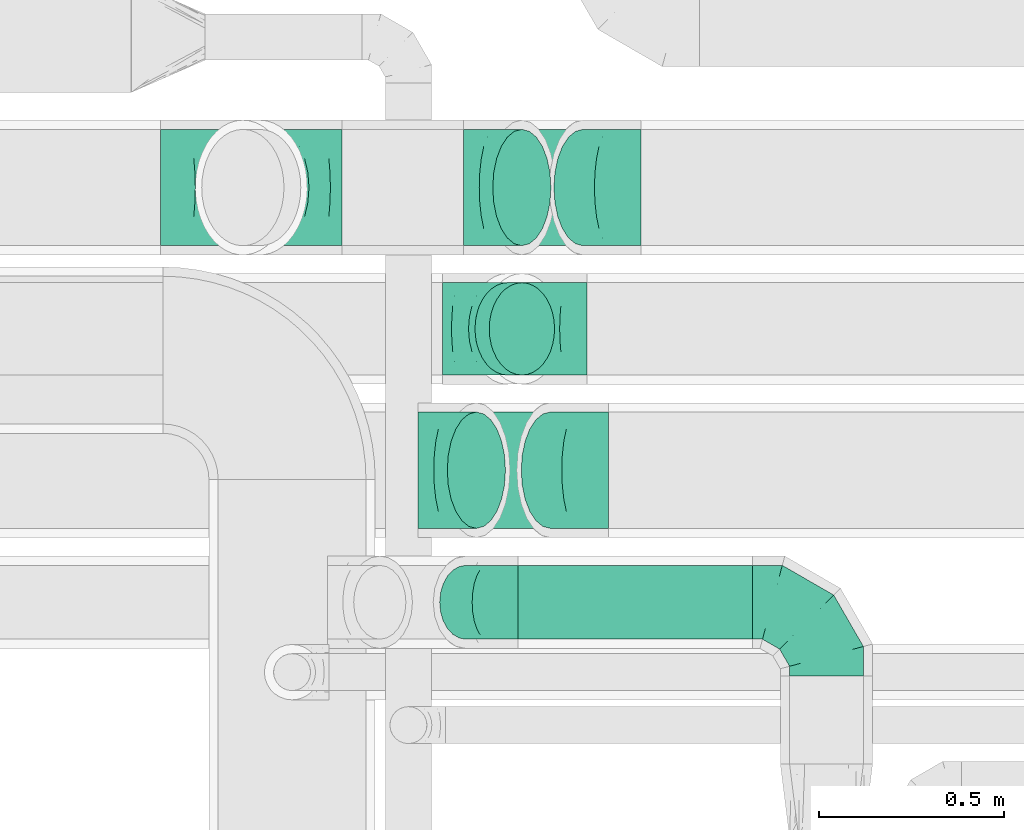
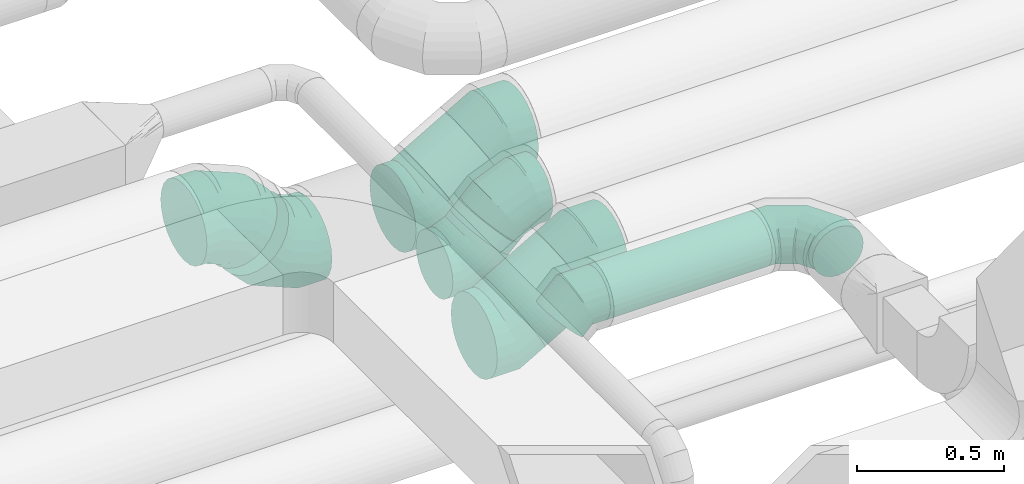
# One storey, part 64 of 92: 10 flow fittings, 4 flow segments.
"""IFC2X3 building model written with IfcOpenShell, lengths in millimetres."""

import ifcopenshell
import ifcopenshell.guid

model = None  # the IFC model being written
_history = None  # IfcOwnerHistory: only IFC2X3 demands one
_inside = {}  # id of a spatial element -> (the spatial element, [elements in it])
_under = {}  # id of a project, library or spatial element -> (it, [spatial elements below it])
_declared = {}  # id of a project -> (the project, [libraries it declares])
_typed = {}  # id of a type object -> (the type object, [elements of that type])
_made_of = {}  # id of a material, layer set ... -> (it, [elements and type objects made of it])


def new_model(schema):
    """Start an empty IFC model of exactly this schema.

    Asked for "IFC4X3", IfcOpenShell would pick the latest addendum, in which some entities
    have other attributes; the version numbers below select the first issue.
    IFC2X3 requires an IfcOwnerHistory on every rooted entity: one is made here for all.
    """
    global model, _history
    if schema == "IFC4X3":
        model = ifcopenshell.file(schema_version=(4, 3, 0, 0))
    else:
        model = ifcopenshell.file(schema=schema)
    _inside.clear()
    _under.clear()
    _declared.clear()
    _typed.clear()
    _made_of.clear()
    _history = None
    if model.schema == "IFC2X3":
        org = make("IfcOrganization", Name="unknown")
        user = make(
            "IfcPersonAndOrganization",
            ThePerson=make("IfcPerson", FamilyName="unknown"),
            TheOrganization=org,
        )
        app = make(
            "IfcApplication",
            ApplicationDeveloper=org,
            Version="unknown",
            ApplicationFullName="unknown",
            ApplicationIdentifier="unknown",
        )
        _history = make(
            "IfcOwnerHistory",
            OwningUser=user,
            OwningApplication=app,
            ChangeAction="ADDED",
            CreationDate=0,
        )
    return model


def make(cls, **values):
    """One entity of the class cls with the attributes given. An attribute that is None is left unset."""
    return model.create_entity(
        cls, **{name: value for name, value in values.items() if value is not None}
    )


def entity(cls, *values):
    """Any entity or typed value of the class cls, its attributes in the order of the schema. None: left unset."""
    e = model.create_entity(cls)
    for i, value in enumerate(values):
        if value is not None:
            e[i] = value
    return e


def rooted(cls, **values):
    """An entity with a GlobalId (a new one), such as an element, a storey or a relation."""
    return make(cls, GlobalId=ifcopenshell.guid.new(), OwnerHistory=_history, **values)


def si_unit(unit_type, name, prefix=None):
    """IfcSIUnit, for example si_unit("LENGTHUNIT", "METRE", prefix="MILLI")."""
    return make("IfcSIUnit", UnitType=unit_type, Prefix=prefix, Name=name)


def converted_unit(unit_type, name, factor, base, dimensions=None, offset=None):
    """IfcConversionBasedUnit, such as the inch: factor (a typed value) times the base unit."""
    return make(
        "IfcConversionBasedUnit"
        if offset is None
        else "IfcConversionBasedUnitWithOffset",
        ConversionOffset=offset,
        Dimensions=None
        if dimensions is None
        else entity("IfcDimensionalExponents", *dimensions),
        UnitType=unit_type,
        Name=name,
        ConversionFactor=make(
            "IfcMeasureWithUnit", ValueComponent=factor, UnitComponent=base
        ),
    )


def derived_unit(unit_type, elements):
    """IfcDerivedUnit: a product of units, each with its exponent."""
    return make(
        "IfcDerivedUnit",
        Elements=[
            make("IfcDerivedUnitElement", Unit=unit, Exponent=power)
            for unit, power in elements
        ],
        UnitType=unit_type,
    )


def assignment(units):
    """IfcUnitAssignment: the units of a project."""
    return None if units is None else make("IfcUnitAssignment", Units=units)


def point(xyz):
    """IfcCartesianPoint."""
    return None if xyz is None else make("IfcCartesianPoint", Coordinates=xyz)


def direction(xyz):
    """IfcDirection."""
    return None if xyz is None else make("IfcDirection", DirectionRatios=xyz)


def frame(location, z_axis=None, x_axis=None):
    """IfcAxis2Placement3D, a coordinate frame: its origin and axes. An axis left out is left unset."""
    return make(
        "IfcAxis2Placement3D",
        Location=point(location),
        Axis=direction(z_axis),
        RefDirection=direction(x_axis),
    )


def frame_2d(location, x_axis=None):
    """IfcAxis2Placement2D, a coordinate frame in the plane: its origin and x axis."""
    return make(
        "IfcAxis2Placement2D", Location=point(location), RefDirection=direction(x_axis)
    )


def origin():
    """The frame at (0, 0, 0) with its axes left unset."""
    return frame((0.0, 0.0, 0.0))


def origin_2d_with_axis():
    """The frame at (0, 0) in the plane with the x axis (1, 0) written out."""
    return frame_2d((0.0, 0.0), x_axis=(1.0, 0.0))


def place(relative_to, where):
    """IfcLocalPlacement: puts the frame where relative to a parent placement (None: the world)."""
    return make(
        "IfcLocalPlacement", PlacementRelTo=relative_to, RelativePlacement=where
    )


def context(
    kind, dimensions, precision=None, world=None, true_north=None, identifier=None
):
    """IfcGeometricRepresentationContext, for example the 3D "Model" context."""
    return make(
        "IfcGeometricRepresentationContext",
        ContextIdentifier=identifier,
        ContextType=kind,
        CoordinateSpaceDimension=dimensions,
        Precision=precision,
        WorldCoordinateSystem=world,
        TrueNorth=true_north,
    )


def subcontext(parent, identifier, kind, view, scale=None):
    """IfcGeometricRepresentationSubContext, for example "Body" below "Model"."""
    return make(
        "IfcGeometricRepresentationSubContext",
        ContextIdentifier=identifier,
        ContextType=kind,
        ParentContext=parent,
        TargetScale=scale,
        TargetView=view,
    )


def project(units=None, contexts=None):
    """IfcProject with its units and contexts."""
    return rooted(
        "IfcProject",
        Name="project",
        RepresentationContexts=contexts,
        UnitsInContext=assignment(units),
    )


def spatial(cls, under=None, at=None, **own):
    """A site, building, storey or space (cls), placed at a placement, below another one or the project."""
    s = rooted(cls, ObjectPlacement=at, **own)
    if under is not None:
        _under.setdefault(under.id(), (under, []))[1].append(s)
    return s


def profile(cls, at=None, kind="AREA", **sizes):
    """A parametric profile (cls). Its sizes go by their IFC names, for example OverallWidth=200.0."""
    return make(cls, ProfileType=kind, Position=at, **sizes)


def circle(**sizes):
    """IfcCircleProfileDef."""
    return profile("IfcCircleProfileDef", **sizes)


def extrude(swept, where, along, depth):
    """IfcExtrudedAreaSolid: the profile swept, set in the frame where, extruded along a direction by depth."""
    return make(
        "IfcExtrudedAreaSolid",
        SweptArea=swept,
        Position=where,
        ExtrudedDirection=direction(along),
        Depth=depth,
    )


def faces_of(points, faces, orient=None, outer=None):
    """IfcFace entities. A face is a list of loops; a loop is a list of indices into points, from 0.

    orient and outer hold one flag for each loop. By default every Orientation is true, the
    first loop of a face is its IfcFaceOuterBound and the others are IfcFaceBound.
    """
    made = []
    for i, loops in enumerate(faces):
        bounds = []
        for j, loop in enumerate(loops):
            is_outer = j == 0 if outer is None else outer[i][j]
            bounds.append(
                make(
                    "IfcFaceOuterBound" if is_outer else "IfcFaceBound",
                    Bound=make("IfcPolyLoop", Polygon=[points[k] for k in loop]),
                    Orientation=True if orient is None else orient[i][j],
                )
            )
        made.append(make("IfcFace", Bounds=bounds))
    return made


def faceted_brep(points, faces, orient=None, outer=None, voids=None):
    """IfcFacetedBrep: a solid bounded by flat faces; with voids (closed shells), ...WithVoids."""
    shared = [point(p) for p in points]
    hull = make("IfcClosedShell", CfsFaces=faces_of(shared, faces, orient, outer))
    if voids is None:
        return make("IfcFacetedBrep", Outer=hull)
    return make(
        "IfcFacetedBrepWithVoids",
        Outer=hull,
        Voids=[
            make(cls, CfsFaces=faces_of(shared, fs, o, b)) for cls, fs, o, b in voids
        ],
    )


def shape(context_of_items, identifier, shape_type, items):
    """IfcShapeRepresentation: the items that make up one representation, for example the "Body"."""
    return make(
        "IfcShapeRepresentation",
        ContextOfItems=context_of_items,
        RepresentationIdentifier=identifier,
        RepresentationType=shape_type,
        Items=items,
    )


def source(mapping_origin, context_of_items, identifier, shape_type, items):
    """IfcRepresentationMap: a shape defined once, which mapped items show again and again."""
    return make(
        "IfcRepresentationMap",
        MappingOrigin=mapping_origin,
        MappedRepresentation=shape(context_of_items, identifier, shape_type, items),
    )


def transform(
    local_origin,
    x_axis=None,
    y_axis=None,
    z_axis=None,
    scale=None,
    scale2=None,
    scale3=None,
    uniform=True,
):
    """IfcCartesianTransformationOperator3D, or its non-uniform kind. x_axis, y_axis, z_axis: its Axis1, 2, 3."""
    if uniform:
        return make(
            "IfcCartesianTransformationOperator3D",
            Axis1=direction(x_axis),
            Axis2=direction(y_axis),
            LocalOrigin=point(local_origin),
            Scale=scale,
            Axis3=direction(z_axis),
        )
    return make(
        "IfcCartesianTransformationOperator3DnonUniform",
        Axis1=direction(x_axis),
        Axis2=direction(y_axis),
        LocalOrigin=point(local_origin),
        Scale=scale,
        Axis3=direction(z_axis),
        Scale2=scale2,
        Scale3=scale3,
    )


def mapped(mapping_source, mapping_target):
    """IfcMappedItem: shows the shape of a source again, moved by a transform."""
    return make(
        "IfcMappedItem", MappingSource=mapping_source, MappingTarget=mapping_target
    )


def material(Name=None, Category=None):
    """IfcMaterial."""
    return make("IfcMaterial", Name=Name, Category=Category)


def made_of(thing, what):
    """Note that an element or type object is made of a material, layer set ...; save() writes the relation."""
    if what is not None:
        _made_of.setdefault(what.id(), (what, []))[1].append(thing)
    return thing


def type_object(cls, material=None, **own):
    """A type object (cls), such as IfcWallType, which elements share."""
    return made_of(rooted(cls, **own), material)


def type_shapes(of_type, sources):
    """Give a type object the sources (RepresentationMaps) that its elements show as mapped items."""
    of_type.RepresentationMaps = sources


def element(
    cls,
    number,
    at=None,
    inside=None,
    cuts=None,
    type_object=None,
    material=None,
    context=None,
    identifier="Body",
    shape_type=None,
    held_by="IfcProductDefinitionShape",
    body=None,
    shapes=None,
    **own,
):
    """One element of the class cls, such as IfcWall. Its Tag is "e" and its number.

    at: its placement. inside: the storey or other place that contains it. cuts: it is an
    opening in that element (IfcRelVoidsElement). A single representation is given by context,
    identifier, shape_type and body (its items); several are given by shapes. held_by: the class
    of the entity that holds the representations. save() writes the other relations.
    """
    e = rooted(cls, Tag="e%d" % number, ObjectPlacement=at, **own)
    if body is not None:
        shapes = [shape(context, identifier, shape_type, body)]
    if shapes is not None:
        e.Representation = make(held_by, Representations=shapes)
    if inside is not None:
        _inside.setdefault(inside.id(), (inside, []))[1].append(e)
    if cuts is not None:
        rooted(
            "IfcRelVoidsElement", RelatingBuildingElement=cuts, RelatedOpeningElement=e
        )
    if type_object is not None:
        _typed.setdefault(type_object.id(), (type_object, []))[1].append(e)
    return made_of(e, material)


def aggregate(whole, parts):
    """IfcRelAggregates: a whole, such as a stair, and the parts it consists of."""
    return rooted("IfcRelAggregates", RelatingObject=whole, RelatedObjects=parts)


def save(model, path):
    """Write the relations noted so far, then the file.

    IfcRelAggregates (storeys below a building ...), IfcRelContainedInSpatialStructure (elements
    in a storey), IfcRelDefinesByType, IfcRelAssociatesMaterial and IfcRelDeclares: one each for
    every whole, place, type object, material and project.
    """
    for whole, parts in _under.values():
        aggregate(whole, parts)
    for where, things in _inside.values():
        rooted(
            "IfcRelContainedInSpatialStructure",
            RelatedElements=things,
            RelatingStructure=where,
        )
    for kind, things in _typed.values():
        rooted("IfcRelDefinesByType", RelatedObjects=things, RelatingType=kind)
    for what, things in _made_of.values():
        rooted("IfcRelAssociatesMaterial", RelatedObjects=things, RelatingMaterial=what)
    for by, libraries in _declared.values():
        rooted("IfcRelDeclares", RelatingContext=by, RelatedDefinitions=libraries)
    model.write(path)


model = new_model("IFC2X3")

# Units and contexts
model_context = context("Model", 3, precision=0.01, world=origin(), true_north=direction((6.12303176911189e-17, 1.0)))
body_context = subcontext(model_context, "Body", "Model", "MODEL_VIEW")
ifc_project = project(units=[si_unit("LENGTHUNIT", "METRE", prefix="MILLI"), si_unit("AREAUNIT", "SQUARE_METRE"), si_unit("VOLUMEUNIT", "CUBIC_METRE"), converted_unit("PLANEANGLEUNIT", "DEGREE", entity("IfcRatioMeasure", 0.0174532925199433), si_unit("PLANEANGLEUNIT", "RADIAN"), dimensions=[0, 0, 0, 0, 0, 0, 0]), si_unit("MASSUNIT", "GRAM", prefix="KILO"), derived_unit("MASSDENSITYUNIT", [(si_unit("MASSUNIT", "GRAM", prefix="KILO"), 1), (si_unit("LENGTHUNIT", "METRE"), -3)]), derived_unit("MOMENTOFINERTIAUNIT", [(si_unit("LENGTHUNIT", "METRE"), 4)]), si_unit("TIMEUNIT", "SECOND"), si_unit("FREQUENCYUNIT", "HERTZ"), si_unit("THERMODYNAMICTEMPERATUREUNIT", "DEGREE_CELSIUS"), derived_unit("THERMALTRANSMITTANCEUNIT", [(si_unit("MASSUNIT", "GRAM", prefix="KILO"), 1), (si_unit("THERMODYNAMICTEMPERATUREUNIT", "KELVIN"), -1), (si_unit("TIMEUNIT", "SECOND"), -3)]), derived_unit("VOLUMETRICFLOWRATEUNIT", [(si_unit("LENGTHUNIT", "METRE"), 3), (si_unit("TIMEUNIT", "SECOND"), -1)]), derived_unit("MASSFLOWRATEUNIT", [(si_unit("MASSUNIT", "GRAM", prefix="KILO"), 1), (si_unit("TIMEUNIT", "SECOND"), -1)]), derived_unit("ROTATIONALFREQUENCYUNIT", [(si_unit("TIMEUNIT", "SECOND"), -1)]), si_unit("ELECTRICCURRENTUNIT", "AMPERE"), si_unit("ELECTRICVOLTAGEUNIT", "VOLT"), si_unit("POWERUNIT", "WATT"), si_unit("FORCEUNIT", "NEWTON", prefix="KILO"), si_unit("ILLUMINANCEUNIT", "LUX"), si_unit("LUMINOUSFLUXUNIT", "LUMEN"), si_unit("LUMINOUSINTENSITYUNIT", "CANDELA"), derived_unit("USERDEFINED", [(si_unit("MASSUNIT", "GRAM", prefix="KILO"), -1), (si_unit("LENGTHUNIT", "METRE"), -2), (si_unit("TIMEUNIT", "SECOND"), 3), (si_unit("LUMINOUSFLUXUNIT", "LUMEN"), 1)]), derived_unit("LINEARVELOCITYUNIT", [(si_unit("LENGTHUNIT", "METRE"), 1), (si_unit("TIMEUNIT", "SECOND"), -1)]), si_unit("PRESSUREUNIT", "PASCAL"), derived_unit("USERDEFINED", [(si_unit("LENGTHUNIT", "METRE"), -2), (si_unit("MASSUNIT", "GRAM", prefix="KILO"), 1), (si_unit("TIMEUNIT", "SECOND"), -2)]), derived_unit("LINEARFORCEUNIT", [(si_unit("MASSUNIT", "GRAM", prefix="KILO"), 1), (si_unit("LENGTHUNIT", "METRE"), 1), (si_unit("TIMEUNIT", "SECOND"), -2), (si_unit("LENGTHUNIT", "METRE"), -1)]), derived_unit("PLANARFORCEUNIT", [(si_unit("MASSUNIT", "GRAM", prefix="KILO"), 1), (si_unit("LENGTHUNIT", "METRE"), 1), (si_unit("TIMEUNIT", "SECOND"), -2), (si_unit("LENGTHUNIT", "METRE"), -2)])], contexts=[model_context])

# Site, building, storey
site_placement = place(None, origin())
site = spatial("IfcSite", under=ifc_project, at=site_placement, CompositionType="ELEMENT")
building_placement = place(site_placement, origin())
building = spatial("IfcBuilding", under=site, at=building_placement, CompositionType="ELEMENT")
storey_placement = place(building_placement, frame((0.0, 0.0, 4200.0)))
storey = spatial("IfcBuildingStorey", under=building, at=storey_placement, CompositionType="ELEMENT", Elevation=4200.0)

# Flow segments
duct_segment_type_1 = type_object("IfcDuctSegmentType", PredefinedType="NOTDEFINED")
flow_segment_1_placement = place(storey_placement, frame((50931.76, 14497.9, 3248.4)))
element("IfcFlowSegment", 1, at=flow_segment_1_placement, inside=storey, type_object=duct_segment_type_1, context=body_context, shape_type="SweptSolid", body=[
    extrude(circle(Radius=100.0, at=origin_2d_with_axis()), frame((0.0, 101.6, 101.6), z_axis=(1.0, 0.0, 0.0), x_axis=(0.0, 1.0, 0.0)), (0.0, 0.0, 1.0), 634.755752735183),
])
flow_segment_2_placement = place(storey_placement, frame((50738.56, 14797.9, 2954.21)))
element("IfcFlowSegment", 2, at=flow_segment_2_placement, inside=storey, type_object=duct_segment_type_1, context=body_context, shape_type="SweptSolid", body=[
    extrude(circle(Radius=157.5, at=origin_2d_with_axis()), frame((80.35, 159.1, 137.99), z_axis=(0.866025337389129, 0.0, 0.500000115000032), x_axis=(0.0, -1.0, 0.0)), (0.0, 0.0, 1.0), 231.191871936207),
])
flow_segment_3_placement = place(storey_placement, frame((50813.63, 15212.9, 3073.24)))
element("IfcFlowSegment", 3, at=flow_segment_3_placement, inside=storey, type_object=duct_segment_type_1, context=body_context, shape_type="SweptSolid", body=[
    extrude(circle(Radius=125.0, at=origin_2d_with_axis()), frame((89.98, 126.6, 89.98), z_axis=(0.707106559498996, 0.0, 0.707107002874029), x_axis=(0.0, -1.0, 0.0)), (0.0, 0.0, 1.0), 54.5225540020971),
])
duct_segment_type_2 = type_object("IfcDuctSegmentType", PredefinedType="NOTDEFINED")
flow_segment_4_placement = place(storey_placement, frame((50861.63, 15562.91, 2974.21)))
element("IfcFlowSegment", 4, at=flow_segment_4_placement, inside=storey, type_object=duct_segment_type_2, context=body_context, shape_type="SweptSolid", body=[
    extrude(circle(Radius=157.5, at=origin_2d_with_axis()), frame((80.35, 159.1, 137.99), z_axis=(0.866025337389111, 0.0, 0.500000115000063), x_axis=(0.0, 1.0, 0.0)), (0.0, 0.0, 1.0), 191.191881136201),
])

# Flow fittings
ifc_material = material()
duct_fitting_type_1 = type_object("IfcDuctFittingType", PredefinedType="NOTDEFINED", material=ifc_material)
shared_shape_1 = source(origin(), body_context, "Body", "Brep", [
    faceted_brep([(-200.0, 0.0, -100.0), (-200.0, -25.88, -96.59), (-200.0, -50.0, -86.6), (-200.0, -70.71, -70.71), (-200.0, -86.6, -50.0), (-200.0, -96.59, -25.88), (-200.0, -100.0, 0.0), (-200.0, -96.59, 25.88), (-200.0, -86.6, 50.0), (-200.0, -70.71, 70.71), (-200.0, -50.0, 86.6), (-200.0, -25.88, 96.59), (-200.0, 0.0, 100.0), (-200.0, 25.88, 96.59), (-200.0, 50.0, 86.6), (-200.0, 70.71, 70.71), (-200.0, 86.6, 50.0), (-200.0, 96.59, 25.88), (-200.0, 100.0, 0.0), (-200.0, 96.59, -25.88), (-200.0, 86.6, -50.0), (-200.0, 70.71, -70.71), (-200.0, 50.0, -86.6), (-200.0, 25.88, -96.59), (-153.35, 25.88, 96.59), (-159.81, 50.0, 86.6), (-146.41, 0.0, 100.0), (-165.36, 70.71, 70.71), (-172.29, 96.59, 25.88), (-173.21, 100.0, 0.0), (-169.62, 86.6, 50.0), (-169.62, 86.6, -50.0), (-165.36, 70.71, -70.71), (-172.29, 96.59, -25.88), (-153.35, 25.88, -96.59), (-146.41, 0.0, -100.0), (-159.81, 50.0, -86.6), (-139.48, -25.88, -96.59), (-133.01, -50.0, -86.6), (-127.46, -70.71, -70.71), (-123.21, -86.6, -50.0), (-120.53, -96.59, -25.88), (-119.62, -100.0, 0.0), (-120.53, -96.59, 25.88), (-123.21, -86.6, 50.0), (-127.46, -70.71, 70.71), (-133.01, -50.0, 86.6), (-139.48, -25.88, 96.59), (-72.54, 72.54, 96.59), (-90.19, 90.19, 86.6), (-53.59, 53.59, 100.0), (-105.35, 105.35, 70.71), (-116.99, 116.99, 50.0), (-124.3, 124.3, 25.88), (-126.79, 126.79, 0.0), (-124.3, 124.3, -25.88), (-116.99, 116.99, -50.0), (-105.35, 105.35, -70.71), (-72.54, 72.54, -96.59), (-53.59, 53.59, -100.0), (-90.19, 90.19, -86.6), (-34.64, 34.64, -96.59), (-16.99, 16.99, -86.6), (-1.83, 1.83, -70.71), (9.81, -9.81, -50.0), (17.12, -17.12, -25.88), (19.62, -19.62, 0.0), (17.12, -17.12, 25.88), (9.81, -9.81, 50.0), (-1.83, 1.83, 70.71), (-16.99, 16.99, 86.6), (-34.64, 34.64, 96.59), (-25.88, 153.35, 96.59), (-50.0, 159.81, 86.6), (0.0, 146.41, 100.0), (-70.71, 165.36, 70.71), (-86.6, 169.62, 50.0), (-96.59, 172.29, 25.88), (-100.0, 173.21, 0.0), (-96.59, 172.29, -25.88), (-86.6, 169.62, -50.0), (-70.71, 165.36, -70.71), (-25.88, 153.35, -96.59), (0.0, 146.41, -100.0), (-50.0, 159.81, -86.6), (25.88, 139.48, -96.59), (50.0, 133.01, -86.6), (70.71, 127.46, -70.71), (86.6, 123.21, -50.0), (96.59, 120.53, -25.88), (100.0, 119.62, 0.0), (96.59, 120.53, 25.88), (86.6, 123.21, 50.0), (70.71, 127.46, 70.71), (50.0, 133.01, 86.6), (25.88, 139.48, 96.59), (-25.88, 200.0, -96.59), (-50.0, 200.0, -86.6), (-70.71, 200.0, -70.71), (-86.6, 200.0, -50.0), (-96.59, 200.0, -25.88), (-100.0, 200.0, 0.0), (-96.59, 200.0, 25.88), (-86.6, 200.0, 50.0), (-70.71, 200.0, 70.71), (-50.0, 200.0, 86.6), (-25.88, 200.0, 96.59), (0.0, 200.0, 100.0), (25.88, 200.0, 96.59), (50.0, 200.0, 86.6), (70.71, 200.0, 70.71), (86.6, 200.0, 50.0), (96.59, 200.0, 25.88), (100.0, 200.0, 0.0), (96.59, 200.0, -25.88), (86.6, 200.0, -50.0), (70.71, 200.0, -70.71), (50.0, 200.0, -86.6), (25.88, 200.0, -96.59), (0.0, 200.0, -100.0)], [[[0, 1, 2, 3, 4, 5, 6, 7, 8, 9, 10, 11, 12, 13, 14, 15, 16, 17, 18, 19, 20, 21, 22, 23]], [[24, 25, 14, 13]], [[26, 24, 13, 12]], [[14, 25, 27, 15]], [[28, 29, 18, 17]], [[30, 28, 17, 16]], [[15, 27, 30, 16]], [[20, 31, 32, 21]], [[33, 31, 20, 19]], [[18, 29, 33, 19]], [[34, 35, 0, 23]], [[36, 34, 23, 22]], [[32, 36, 22, 21]], [[1, 0, 35, 37]], [[2, 1, 37, 38]], [[38, 39, 3, 2]], [[5, 4, 40, 41]], [[6, 5, 41, 42]], [[39, 40, 4, 3]], [[6, 42, 43, 7]], [[7, 43, 44, 8]], [[8, 44, 45, 9]], [[9, 45, 46, 10]], [[10, 46, 47, 11]], [[26, 12, 11, 47]], [[48, 49, 25, 24]], [[50, 48, 24, 26]], [[27, 25, 49, 51]], [[52, 53, 28, 30]], [[51, 52, 30, 27]], [[29, 28, 53, 54]], [[55, 56, 31, 33]], [[54, 55, 33, 29]], [[32, 31, 56, 57]], [[58, 59, 35, 34]], [[60, 58, 34, 36]], [[57, 60, 36, 32]], [[37, 35, 59, 61]], [[38, 37, 61, 62]], [[39, 38, 62, 63]], [[41, 40, 64, 65]], [[42, 41, 65, 66]], [[63, 64, 40, 39]], [[43, 42, 66, 67]], [[44, 43, 67, 68]], [[68, 69, 45, 44]], [[46, 45, 69, 70]], [[47, 46, 70, 71]], [[26, 47, 71, 50]], [[72, 73, 49, 48]], [[74, 72, 48, 50]], [[51, 49, 73, 75]], [[76, 77, 53, 52]], [[75, 76, 52, 51]], [[54, 53, 77, 78]], [[79, 80, 56, 55]], [[78, 79, 55, 54]], [[57, 56, 80, 81]], [[82, 83, 59, 58]], [[84, 82, 58, 60]], [[81, 84, 60, 57]], [[61, 59, 83, 85]], [[62, 61, 85, 86]], [[63, 62, 86, 87]], [[65, 64, 88, 89]], [[66, 65, 89, 90]], [[87, 88, 64, 63]], [[67, 66, 90, 91]], [[68, 67, 91, 92]], [[92, 93, 69, 68]], [[70, 69, 93, 94]], [[71, 70, 94, 95]], [[50, 71, 95, 74]], [[96, 97, 98, 99, 100, 101, 102, 103, 104, 105, 106, 107, 108, 109, 110, 111, 112, 113, 114, 115, 116, 117, 118, 119]], [[72, 74, 107, 106]], [[73, 72, 106, 105]], [[75, 73, 105, 104]], [[102, 101, 78, 77]], [[103, 102, 77, 76]], [[75, 104, 103, 76]], [[78, 101, 100, 79]], [[79, 100, 99, 80]], [[80, 99, 98, 81]], [[84, 97, 96, 82]], [[82, 96, 119, 83]], [[84, 81, 98, 97]], [[118, 117, 86, 85]], [[119, 118, 85, 83]], [[116, 87, 86, 117]], [[88, 115, 114, 89]], [[89, 114, 113, 90]], [[115, 88, 87, 116]], [[91, 90, 113, 112]], [[92, 91, 112, 111]], [[111, 110, 93, 92]], [[95, 94, 109, 108]], [[74, 95, 108, 107]], [[110, 109, 94, 93]]]),
])
type_shapes(duct_fitting_type_1, [shared_shape_1])
flow_fitting_1_placement = place(storey_placement, frame((51766.52, 14599.5, 3350.0), z_axis=(0.0, 0.0, 1.0), x_axis=(0.0, 1.0, 0.0)))
element("IfcFlowFitting", 5, at=flow_fitting_1_placement, inside=storey, type_object=duct_fitting_type_1, material=ifc_material, context=body_context, shape_type="MappedRepresentation", body=[
    mapped(shared_shape_1, transform((0.0, 0.0, 0.0), scale=1.0)),
])
duct_fitting_type_2 = type_object("IfcDuctFittingType", PredefinedType="NOTDEFINED", material=ifc_material)
shared_shape_2 = source(origin(), body_context, "Body", "Brep", [
    faceted_brep([(-82.84, 0.0, -100.0), (-82.84, -25.88, -96.59), (-82.84, -50.0, -86.6), (-82.84, -70.71, -70.71), (-82.84, -86.6, -50.0), (-82.84, -96.59, -25.88), (-82.84, -100.0, 0.0), (-82.84, -96.59, 25.88), (-82.84, -86.6, 50.0), (-82.84, -70.71, 70.71), (-82.84, -50.0, 86.6), (-82.84, -25.88, 96.59), (-82.84, 0.0, 100.0), (-82.84, 25.88, 96.59), (-82.84, 50.0, 86.6), (-82.84, 70.71, 70.71), (-82.84, 86.6, 50.0), (-82.84, 96.59, 25.88), (-82.84, 100.0, 0.0), (-82.84, 96.59, -25.88), (-82.84, 86.6, -50.0), (-82.84, 70.71, -70.71), (-82.84, 50.0, -86.6), (-82.84, 25.88, -96.59), (-10.72, 25.88, 96.59), (-20.71, 50.0, 86.6), (0.0, 0.0, 100.0), (-29.29, 70.71, 70.71), (-35.87, 86.6, 50.0), (-40.01, 96.59, 25.88), (-41.42, 100.0, 0.0), (-40.01, 96.59, -25.88), (-35.87, 86.6, -50.0), (-29.29, 70.71, -70.71), (-10.72, 25.88, -96.59), (0.0, 0.0, -100.0), (-20.71, 50.0, -86.6), (10.72, -25.88, -96.59), (20.71, -50.0, -86.6), (29.29, -70.71, -70.71), (35.87, -86.6, -50.0), (40.01, -96.59, -25.88), (41.42, -100.0, 0.0), (40.01, -96.59, 25.88), (35.87, -86.6, 50.0), (29.29, -70.71, 70.71), (20.71, -50.0, 86.6), (10.72, -25.88, 96.59), (58.58, 58.58, 100.0), (40.28, 76.88, 96.59), (23.22, 93.93, 86.6), (8.58, 108.58, 70.71), (-2.66, 119.82, 50.0), (-9.72, 126.88, 25.88), (-12.13, 129.29, 0.0), (-9.72, 126.88, -25.88), (-2.66, 119.82, -50.0), (8.58, 108.58, -70.71), (23.22, 93.93, -86.6), (40.28, 76.88, -96.59), (58.58, 58.58, -100.0), (76.88, 40.28, -96.59), (93.93, 23.22, -86.6), (108.58, 8.58, -70.71), (119.82, -2.66, -50.0), (126.88, -9.72, -25.88), (129.29, -12.13, 0.0), (126.88, -9.72, 25.88), (119.82, -2.66, 50.0), (108.58, 8.58, 70.71), (93.93, 23.22, 86.6), (76.88, 40.28, 96.59)], [[[0, 1, 2, 3, 4, 5, 6, 7, 8, 9, 10, 11, 12, 13, 14, 15, 16, 17, 18, 19, 20, 21, 22, 23]], [[24, 25, 14, 13]], [[26, 24, 13, 12]], [[14, 25, 27, 15]], [[28, 29, 17, 16]], [[28, 16, 15, 27]], [[30, 18, 17, 29]], [[31, 32, 20, 19]], [[30, 31, 19, 18]], [[32, 33, 21, 20]], [[34, 35, 0, 23]], [[36, 34, 23, 22]], [[33, 36, 22, 21]], [[1, 0, 35, 37]], [[2, 1, 37, 38]], [[38, 39, 3, 2]], [[5, 4, 40, 41]], [[6, 5, 41, 42]], [[39, 40, 4, 3]], [[6, 42, 43, 7]], [[7, 43, 44, 8]], [[8, 44, 45, 9]], [[9, 45, 46, 10]], [[10, 46, 47, 11]], [[26, 12, 11, 47]], [[24, 26, 48, 49]], [[25, 24, 49, 50]], [[27, 25, 50, 51]], [[29, 28, 52, 53]], [[30, 29, 53, 54]], [[51, 52, 28, 27]], [[30, 54, 55, 31]], [[31, 55, 56, 32]], [[57, 33, 32, 56]], [[36, 58, 59, 34]], [[34, 59, 60, 35]], [[58, 36, 33, 57]], [[35, 60, 61, 37]], [[37, 61, 62, 38]], [[63, 39, 38, 62]], [[40, 64, 65, 41]], [[41, 65, 66, 42]], [[64, 40, 39, 63]], [[43, 42, 66, 67]], [[44, 43, 67, 68]], [[68, 69, 45, 44]], [[47, 46, 70, 71]], [[26, 47, 71, 48]], [[69, 70, 46, 45]], [[59, 58, 57, 56, 55, 54, 53, 52, 51, 50, 49, 48, 71, 70, 69, 68, 67, 66, 65, 64, 63, 62, 61, 60]]]),
])
type_shapes(duct_fitting_type_2, [shared_shape_2])
flow_fitting_2_placement = place(storey_placement, frame((50848.92, 14599.5, 3350.0), z_axis=(0.0, -1.0, 0.0), x_axis=(-1.0, 0.0, 0.0)))
element("IfcFlowFitting", 6, at=flow_fitting_2_placement, inside=storey, type_object=duct_fitting_type_2, material=ifc_material, context=body_context, shape_type="MappedRepresentation", body=[
    mapped(shared_shape_2, transform((0.0, 0.0, 0.0), scale=1.0)),
])
duct_fitting_type_3 = type_object("IfcDuctFittingType", PredefinedType="NOTDEFINED", material=ifc_material)
shared_shape_3 = source(origin(), body_context, "Body", "Brep", [
    faceted_brep([(-84.4, 0.0, -157.5), (-84.4, -40.76, -152.13), (-84.4, -78.75, -136.4), (-84.4, -111.37, -111.37), (-84.4, -136.4, -78.75), (-84.4, -152.13, -40.76), (-84.4, -157.5, 0.0), (-84.4, -152.13, 40.76), (-84.4, -136.4, 78.75), (-84.4, -111.37, 111.37), (-84.4, -78.75, 136.4), (-84.4, -40.76, 152.13), (-84.4, 0.0, 157.5), (-84.4, 40.76, 152.13), (-84.4, 78.75, 136.4), (-84.4, 111.37, 111.37), (-84.4, 136.4, 78.75), (-84.4, 152.13, 40.76), (-84.4, 157.5, 0.0), (-84.4, 152.13, -40.76), (-84.4, 136.4, -78.75), (-84.4, 111.37, -111.37), (-84.4, 78.75, -136.4), (-84.4, 40.76, -152.13), (-10.92, 40.76, 152.13), (-21.1, 78.75, 136.4), (0.0, 0.0, 157.5), (-29.84, 111.37, 111.37), (-40.76, 152.13, 40.76), (-42.2, 157.5, 0.0), (-36.55, 136.4, 78.75), (-36.55, 136.4, -78.75), (-29.84, 111.37, -111.37), (-40.76, 152.13, -40.76), (-10.92, 40.76, -152.13), (0.0, 0.0, -157.5), (-21.1, 78.75, -136.4), (10.92, -40.76, -152.13), (21.1, -78.75, -136.4), (29.84, -111.37, -111.37), (36.55, -136.4, -78.75), (40.76, -152.13, -40.76), (42.2, -157.5, 0.0), (40.76, -152.13, 40.76), (36.55, -136.4, 78.75), (29.84, -111.37, 111.37), (21.1, -78.75, 136.4), (10.92, -40.76, 152.13), (52.71, 77.5, 152.13), (33.72, 110.4, 136.4), (73.1, 42.2, 157.5), (17.41, 138.65, 111.37), (4.9, 160.33, 78.75), (-2.97, 173.95, 40.76), (-5.65, 178.6, 0.0), (-2.97, 173.95, -40.76), (4.9, 160.33, -78.75), (17.41, 138.65, -111.37), (33.72, 110.4, -136.4), (52.71, 77.5, -152.13), (73.1, 42.2, -157.5), (93.48, 6.9, -152.13), (112.47, -26.0, -136.4), (128.78, -54.25, -111.37), (141.3, -75.92, -78.75), (149.16, -89.55, -40.76), (151.85, -94.2, 0.0), (149.16, -89.55, 40.76), (141.3, -75.92, 78.75), (128.78, -54.25, 111.37), (112.47, -26.0, 136.4), (93.48, 6.9, 152.13)], [[[0, 1, 2, 3, 4, 5, 6, 7, 8, 9, 10, 11, 12, 13, 14, 15, 16, 17, 18, 19, 20, 21, 22, 23]], [[24, 25, 14, 13]], [[26, 24, 13, 12]], [[14, 25, 27, 15]], [[28, 29, 18, 17]], [[30, 28, 17, 16]], [[15, 27, 30, 16]], [[20, 31, 32, 21]], [[33, 31, 20, 19]], [[18, 29, 33, 19]], [[34, 35, 0, 23]], [[36, 34, 23, 22]], [[32, 36, 22, 21]], [[1, 0, 35, 37]], [[2, 1, 37, 38]], [[38, 39, 3, 2]], [[5, 4, 40, 41]], [[6, 5, 41, 42]], [[39, 40, 4, 3]], [[6, 42, 43, 7]], [[7, 43, 44, 8]], [[8, 44, 45, 9]], [[9, 45, 46, 10]], [[10, 46, 47, 11]], [[26, 12, 11, 47]], [[48, 49, 25, 24]], [[50, 48, 24, 26]], [[27, 25, 49, 51]], [[28, 30, 52, 53]], [[29, 28, 53, 54]], [[51, 52, 30, 27]], [[29, 54, 55, 33]], [[33, 55, 56, 31]], [[57, 32, 31, 56]], [[36, 58, 59, 34]], [[34, 59, 60, 35]], [[58, 36, 32, 57]], [[35, 60, 61, 37]], [[37, 61, 62, 38]], [[63, 39, 38, 62]], [[40, 64, 65, 41]], [[41, 65, 66, 42]], [[64, 40, 39, 63]], [[43, 42, 66, 67]], [[44, 43, 67, 68]], [[68, 69, 45, 44]], [[47, 46, 70, 71]], [[26, 47, 71, 50]], [[69, 70, 46, 45]], [[59, 58, 57, 56, 55, 54, 53, 52, 51, 49, 48, 50, 71, 70, 69, 68, 67, 66, 65, 64, 63, 62, 61, 60]]]),
])
type_shapes(duct_fitting_type_3, [shared_shape_3])
for number, where, z_axis, x_axis in (
    (7, (50745.81, 14957.0, 3050.0), (0.0, -1.0, 0.0), (1.0, 0.0, 0.0)),
    (8, (51092.22, 14957.0, 3250.0), (0.0, 1.0, 0.0), (0.866025337389099, 0.0, 0.500000115000085)),
    (9, (51180.65, 15722.0, 3250.0), (0.0, -1.0, 0.0), (-1.0, 0.0, 0.0)),
    (10, (50868.88, 15722.0, 3070.0), (0.0, 1.0, 0.0), (-0.866025337389104, 0.0, -0.500000115000076)),
):
    element("IfcFlowFitting", number, at=place(storey_placement, frame(where, z_axis=z_axis, x_axis=x_axis)), inside=storey, type_object=duct_fitting_type_3, material=ifc_material, context=body_context, shape_type="MappedRepresentation", body=[
        mapped(shared_shape_3, transform((0.0, 0.0, 0.0), scale=1.0)),
    ])
duct_fitting_type_4 = type_object("IfcDuctFittingType", PredefinedType="NOTDEFINED", material=ifc_material)
shared_shape_4 = source(origin(), body_context, "Body", "Brep", [
    faceted_brep([(-103.55, 0.0, -125.0), (-103.55, -32.35, -120.74), (-103.55, -62.5, -108.25), (-103.55, -88.39, -88.39), (-103.55, -108.25, -62.5), (-103.55, -120.74, -32.35), (-103.55, -125.0, 0.0), (-103.55, -120.74, 32.35), (-103.55, -108.25, 62.5), (-103.55, -88.39, 88.39), (-103.55, -62.5, 108.25), (-103.55, -32.35, 120.74), (-103.55, 0.0, 125.0), (-103.55, 32.35, 120.74), (-103.55, 62.5, 108.25), (-103.55, 88.39, 88.39), (-103.55, 108.25, 62.5), (-103.55, 120.74, 32.35), (-103.55, 125.0, 0.0), (-103.55, 120.74, -32.35), (-103.55, 108.25, -62.5), (-103.55, 88.39, -88.39), (-103.55, 62.5, -108.25), (-103.55, 32.35, -120.74), (-60.26, 32.35, 120.74), (-66.26, 62.5, 108.25), (-53.83, 0.0, 125.0), (-71.41, 88.39, 88.39), (-77.84, 120.74, 32.35), (-78.69, 125.0, 0.0), (-75.36, 108.25, 62.5), (-75.36, 108.25, -62.5), (-71.41, 88.39, -88.39), (-77.84, 120.74, -32.35), (-60.26, 32.35, -120.74), (-53.83, 0.0, -125.0), (-66.26, 62.5, -108.25), (-47.39, -32.35, -120.74), (-41.39, -62.5, -108.25), (-36.24, -88.39, -88.39), (-32.29, -108.25, -62.5), (-29.81, -120.74, -32.35), (-28.96, -125.0, 0.0), (-29.81, -120.74, 32.35), (-32.29, -108.25, 62.5), (-36.24, -88.39, 88.39), (-41.39, -62.5, 108.25), (-47.39, -32.35, 120.74), (19.73, 65.49, 120.74), (2.66, 91.05, 108.25), (38.06, 38.06, 125.0), (-12.01, 112.99, 88.39), (-23.26, 129.83, 62.5), (-30.33, 140.42, 32.35), (-32.75, 144.03, 0.0), (-30.33, 140.42, -32.35), (-23.26, 129.83, -62.5), (-12.01, 112.99, -88.39), (19.73, 65.49, -120.74), (38.06, 38.06, -125.0), (2.66, 91.05, -108.25), (56.39, 10.63, -120.74), (73.46, -14.92, -108.25), (88.13, -36.87, -88.39), (99.38, -53.71, -62.5), (106.45, -64.3, -32.35), (108.87, -67.91, 0.0), (106.45, -64.3, 32.35), (99.38, -53.71, 62.5), (88.13, -36.87, 88.39), (73.46, -14.92, 108.25), (56.39, 10.63, 120.74), (73.22, 73.22, 125.0), (50.35, 96.1, 120.74), (29.03, 117.42, 108.25), (10.72, 135.72, 88.39), (-3.32, 149.77, 62.5), (-12.15, 158.6, 32.35), (-15.17, 161.61, 0.0), (-12.15, 158.6, -32.35), (-3.32, 149.77, -62.5), (10.72, 135.72, -88.39), (29.03, 117.42, -108.25), (50.35, 96.1, -120.74), (73.22, 73.22, -125.0), (96.1, 50.35, -120.74), (117.42, 29.03, -108.25), (135.72, 10.72, -88.39), (149.77, -3.32, -62.5), (158.6, -12.15, -32.35), (161.61, -15.16, 0.0), (158.6, -12.15, 32.35), (149.77, -3.32, 62.5), (135.72, 10.72, 88.39), (117.42, 29.03, 108.25), (96.1, 50.35, 120.74)], [[[0, 1, 2, 3, 4, 5, 6, 7, 8, 9, 10, 11, 12, 13, 14, 15, 16, 17, 18, 19, 20, 21, 22, 23]], [[24, 25, 14, 13]], [[26, 24, 13, 12]], [[14, 25, 27, 15]], [[28, 29, 18, 17]], [[30, 28, 17, 16]], [[15, 27, 30, 16]], [[20, 31, 32, 21]], [[33, 31, 20, 19]], [[18, 29, 33, 19]], [[34, 35, 0, 23]], [[36, 34, 23, 22]], [[32, 36, 22, 21]], [[1, 0, 35, 37]], [[2, 1, 37, 38]], [[3, 2, 38, 39]], [[5, 4, 40, 41]], [[6, 5, 41, 42]], [[39, 40, 4, 3]], [[6, 42, 43, 7]], [[7, 43, 44, 8]], [[45, 9, 8, 44]], [[9, 45, 46, 10]], [[10, 46, 47, 11]], [[26, 12, 11, 47]], [[48, 49, 25, 24]], [[50, 48, 24, 26]], [[27, 25, 49, 51]], [[52, 53, 28, 30]], [[51, 52, 30, 27]], [[29, 28, 53, 54]], [[55, 56, 31, 33]], [[54, 55, 33, 29]], [[32, 31, 56, 57]], [[58, 59, 35, 34]], [[60, 58, 34, 36]], [[57, 60, 36, 32]], [[37, 35, 59, 61]], [[38, 37, 61, 62]], [[39, 38, 62, 63]], [[41, 40, 64, 65]], [[42, 41, 65, 66]], [[63, 64, 40, 39]], [[43, 42, 66, 67]], [[44, 43, 67, 68]], [[68, 69, 45, 44]], [[46, 45, 69, 70]], [[47, 46, 70, 71]], [[26, 47, 71, 50]], [[48, 50, 72, 73]], [[49, 48, 73, 74]], [[51, 49, 74, 75]], [[53, 52, 76, 77]], [[54, 53, 77, 78]], [[51, 75, 76, 52]], [[54, 78, 79, 55]], [[55, 79, 80, 56]], [[56, 80, 81, 57]], [[60, 82, 83, 58]], [[58, 83, 84, 59]], [[60, 57, 81, 82]], [[59, 84, 85, 61]], [[61, 85, 86, 62]], [[87, 63, 62, 86]], [[64, 88, 89, 65]], [[65, 89, 90, 66]], [[88, 64, 63, 87]], [[91, 92, 68, 67]], [[90, 91, 67, 66]], [[92, 93, 69, 68]], [[71, 70, 94, 95]], [[50, 71, 95, 72]], [[93, 94, 70, 69]], [[83, 82, 81, 80, 79, 78, 77, 76, 75, 74, 73, 72, 95, 94, 93, 92, 91, 90, 89, 88, 87, 86, 85, 84]]]),
])
type_shapes(duct_fitting_type_4, [shared_shape_4])
for number, where, z_axis, x_axis in (
    (11, (50830.39, 15339.5, 3090.0), (0.0, -1.0, 0.0), (1.0, 0.0, 0.0)),
    (12, (51015.39, 15339.5, 3275.0), (0.0, 1.0, 0.0), (0.707106559498762, 0.0, 0.707107002874264)),
):
    element("IfcFlowFitting", number, at=place(storey_placement, frame(where, z_axis=z_axis, x_axis=x_axis)), inside=storey, type_object=duct_fitting_type_4, material=ifc_material, context=body_context, shape_type="MappedRepresentation", body=[
        mapped(shared_shape_4, transform((0.0, 0.0, 0.0), scale=1.0)),
    ])
duct_fitting_type_5 = type_object("IfcDuctFittingType", PredefinedType="NOTDEFINED", material=ifc_material)
shared_shape_5 = source(origin(), body_context, "Body", "Brep", [
    faceted_brep([(-130.48, 0.0, -157.5), (-130.48, -40.76, -152.13), (-130.48, -78.75, -136.4), (-130.48, -111.37, -111.37), (-130.48, -136.4, -78.75), (-130.48, -152.13, -40.76), (-130.48, -157.5, 0.0), (-130.48, -152.13, 40.76), (-130.48, -136.4, 78.75), (-130.48, -111.37, 111.37), (-130.48, -78.75, 136.4), (-130.48, -40.76, 152.13), (-130.48, 0.0, 157.5), (-130.48, 40.76, 152.13), (-130.48, 78.75, 136.4), (-130.48, 111.37, 111.37), (-130.48, 136.4, 78.75), (-130.48, 152.13, 40.76), (-130.48, 157.5, 0.0), (-130.48, 152.13, -40.76), (-130.48, 136.4, -78.75), (-130.48, 111.37, -111.37), (-130.48, 78.75, -136.4), (-130.48, 40.76, -152.13), (-75.93, 40.76, 152.13), (-83.48, 78.75, 136.4), (-67.82, 0.0, 157.5), (-89.97, 111.37, 111.37), (-94.95, 136.4, 78.75), (-98.08, 152.13, 40.76), (-99.15, 157.5, 0.0), (-98.08, 152.13, -40.76), (-94.95, 136.4, -78.75), (-89.97, 111.37, -111.37), (-75.93, 40.76, -152.13), (-67.82, 0.0, -157.5), (-83.48, 78.75, -136.4), (-59.71, -40.76, -152.13), (-52.16, -78.75, -136.4), (-45.67, -111.37, -111.37), (-40.69, -136.4, -78.75), (-37.56, -152.13, -40.76), (-36.49, -157.5, 0.0), (-37.56, -152.13, 40.76), (-40.69, -136.4, 78.75), (-45.67, -111.37, 111.37), (-52.16, -78.75, 136.4), (-59.71, -40.76, 152.13), (24.86, 82.51, 152.13), (3.35, 114.72, 136.4), (47.96, 47.96, 157.5), (-15.13, 142.37, 111.37), (-29.31, 163.59, 78.75), (-38.22, 176.93, 40.76), (-41.26, 181.48, 0.0), (-38.22, 176.93, -40.76), (-29.31, 163.59, -78.75), (-15.13, 142.37, -111.37), (24.86, 82.51, -152.13), (47.96, 47.96, -157.5), (3.35, 114.72, -136.4), (71.05, 13.4, -152.13), (92.56, -18.81, -136.4), (111.04, -46.46, -111.37), (125.22, -67.68, -78.75), (134.13, -81.02, -40.76), (137.17, -85.57, 0.0), (134.13, -81.02, 40.76), (125.22, -67.68, 78.75), (111.04, -46.46, 111.37), (92.56, -18.81, 136.4), (71.05, 13.4, 152.13), (92.26, 92.26, 157.5), (63.44, 121.09, 152.13), (36.58, 147.95, 136.4), (13.51, 171.01, 111.37), (-4.19, 188.71, 78.75), (-15.31, 199.84, 40.76), (-19.11, 203.63, 0.0), (-15.31, 199.84, -40.76), (-4.19, 188.71, -78.75), (13.51, 171.01, -111.37), (36.58, 147.95, -136.4), (63.44, 121.09, -152.13), (92.26, 92.26, -157.5), (121.09, 63.44, -152.13), (147.95, 36.58, -136.4), (171.01, 13.51, -111.37), (188.71, -4.19, -78.75), (199.84, -15.31, -40.76), (203.63, -19.11, 0.0), (199.84, -15.31, 40.76), (188.71, -4.19, 78.75), (171.01, 13.51, 111.37), (147.95, 36.58, 136.4), (121.09, 63.44, 152.13)], [[[0, 1, 2, 3, 4, 5, 6, 7, 8, 9, 10, 11, 12, 13, 14, 15, 16, 17, 18, 19, 20, 21, 22, 23]], [[24, 25, 14, 13]], [[26, 24, 13, 12]], [[27, 15, 14, 25]], [[28, 29, 17, 16]], [[28, 16, 15, 27]], [[30, 18, 17, 29]], [[31, 32, 20, 19]], [[30, 31, 19, 18]], [[21, 20, 32, 33]], [[34, 35, 0, 23]], [[36, 34, 23, 22]], [[33, 36, 22, 21]], [[1, 0, 35, 37]], [[2, 1, 37, 38]], [[3, 2, 38, 39]], [[5, 4, 40, 41]], [[6, 5, 41, 42]], [[39, 40, 4, 3]], [[6, 42, 43, 7]], [[7, 43, 44, 8]], [[45, 9, 8, 44]], [[9, 45, 46, 10]], [[10, 46, 47, 11]], [[26, 12, 11, 47]], [[48, 49, 25, 24]], [[50, 48, 24, 26]], [[27, 25, 49, 51]], [[52, 53, 29, 28]], [[51, 52, 28, 27]], [[30, 29, 53, 54]], [[55, 56, 32, 31]], [[54, 55, 31, 30]], [[33, 32, 56, 57]], [[58, 59, 35, 34]], [[60, 58, 34, 36]], [[57, 60, 36, 33]], [[37, 35, 59, 61]], [[38, 37, 61, 62]], [[39, 38, 62, 63]], [[41, 40, 64, 65]], [[42, 41, 65, 66]], [[63, 64, 40, 39]], [[43, 42, 66, 67]], [[44, 43, 67, 68]], [[68, 69, 45, 44]], [[46, 45, 69, 70]], [[47, 46, 70, 71]], [[26, 47, 71, 50]], [[48, 50, 72, 73]], [[49, 48, 73, 74]], [[51, 49, 74, 75]], [[53, 52, 76, 77]], [[54, 53, 77, 78]], [[51, 75, 76, 52]], [[54, 78, 79, 55]], [[55, 79, 80, 56]], [[56, 80, 81, 57]], [[60, 82, 83, 58]], [[58, 83, 84, 59]], [[60, 57, 81, 82]], [[85, 86, 62, 61]], [[84, 85, 61, 59]], [[87, 63, 62, 86]], [[64, 88, 89, 65]], [[65, 89, 90, 66]], [[88, 64, 63, 87]], [[91, 92, 68, 67]], [[90, 91, 67, 66]], [[92, 93, 69, 68]], [[71, 70, 94, 95]], [[50, 71, 95, 72]], [[93, 94, 70, 69]], [[83, 82, 81, 80, 79, 78, 77, 76, 75, 74, 73, 72, 95, 94, 93, 92, 91, 90, 89, 88, 87, 86, 85, 84]]]),
])
type_shapes(duct_fitting_type_5, [shared_shape_5])
for number, where, z_axis, x_axis in (
    (13, (50094.65, 15722.0, 3300.0), (0.0, 1.0, 0.0), (1.0, 0.0, 0.0)),
    (14, (50324.65, 15722.0, 3070.0), (0.0, -1.0, 0.0), (0.707106698793171, 0.0, -0.707106863579914)),
):
    element("IfcFlowFitting", number, at=place(storey_placement, frame(where, z_axis=z_axis, x_axis=x_axis)), inside=storey, type_object=duct_fitting_type_5, material=ifc_material, context=body_context, shape_type="MappedRepresentation", body=[
        mapped(shared_shape_5, transform((0.0, 0.0, 0.0), scale=1.0)),
    ])

save(model, "model.ifc")
